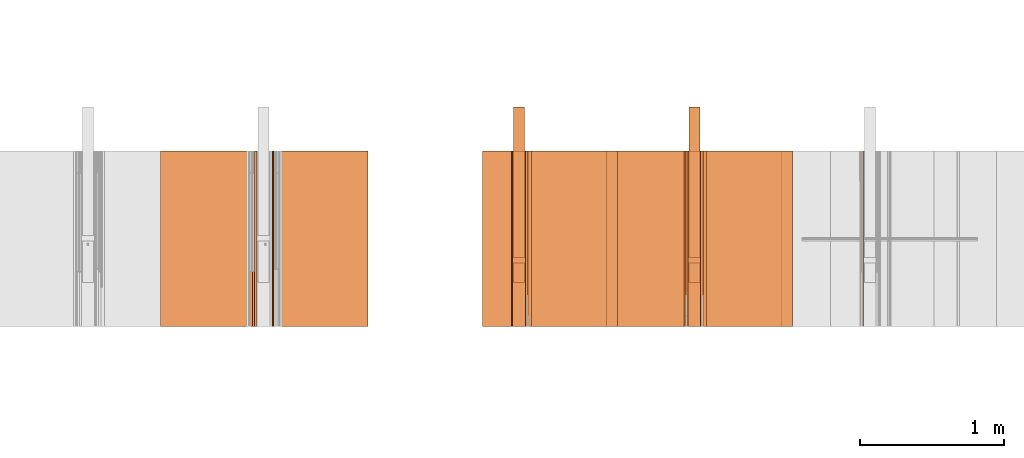
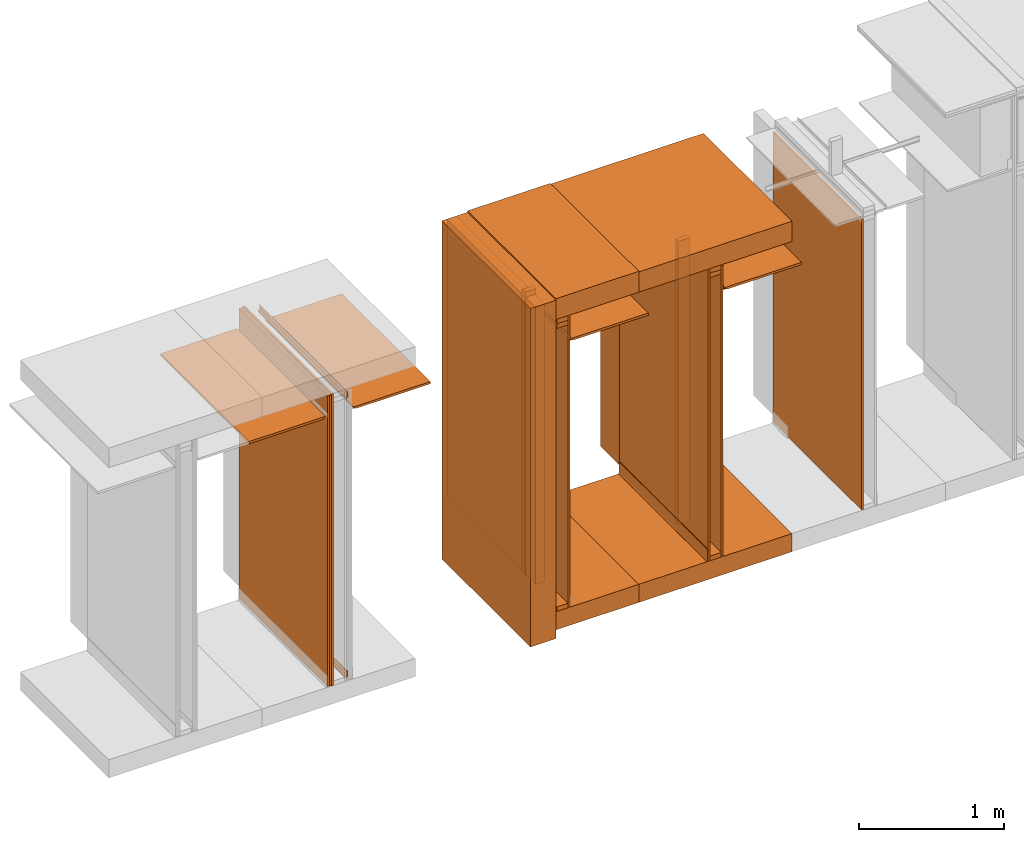
# One storey, part 33 of 64: 31 proxies.
"""IFC4 building model written with IfcOpenShell, lengths in feet."""

from ifc_helpers import new_model, entity, si_unit, converted_unit, frame, origin_with_axes, origin_2d_with_axis, place, context, subcontext, project, spatial, polyline, line, indexed_curve, outline, extrude, material, constituent, constituent_set, element, save


model = new_model("IFC4")

# Units and contexts
model_context_1 = context("Model", 3, precision=1e-05, world=origin_with_axes())
plan_context = context("Plan", 2, precision=1e-05, world=origin_2d_with_axis())
model_context_2 = context("Model", 3, precision=1e-05, world=origin_with_axes())
context_of_model_1 = context(None, 3, precision=1e-05, world=origin_with_axes())
context_of_model_2 = context(None, 3, precision=1e-05, world=origin_with_axes())
body_context = subcontext(model_context_2, "Body", "Model", "MODEL_VIEW")
ifc_project = project(units=[converted_unit("PLANEANGLEUNIT", "degree", entity("IfcReal", 0.0174532925199433), si_unit("PLANEANGLEUNIT", "RADIAN"), dimensions=[0, 0, 0, 0, 0, 0, 0]), converted_unit("AREAUNIT", "square foot", entity("IfcReal", 0.09290304), si_unit("AREAUNIT", "SQUARE_METRE"), dimensions=[2, 0, 0, 0, 0, 0, 0]), converted_unit("LENGTHUNIT", "foot", entity("IfcReal", 0.3048), si_unit("LENGTHUNIT", "METRE"), dimensions=[1, 0, 0, 0, 0, 0, 0]), converted_unit("VOLUMEUNIT", "cubic foot", entity("IfcReal", 0.0283168467116885), si_unit("VOLUMEUNIT", "CUBIC_METRE"), dimensions=[3, 0, 0, 0, 0, 0, 0])], contexts=[model_context_1, plan_context, context_of_model_1, context_of_model_2])

# Site, building, storey
site_placement = place(None, origin_with_axes())
site = spatial("IfcSite", under=ifc_project, at=site_placement)
building_placement = place(site_placement, origin_with_axes())
building = spatial("IfcBuilding", under=site, at=building_placement, Name="Building")
storey_placement = place(building_placement, origin_with_axes())
storey = spatial("IfcBuildingStorey", under=building, at=storey_placement, Name="Storey")

# Proxies
ifc_material_1 = material(Category="sand")
proxy_1_placement = place(storey_placement, frame((1378.99323711245, 5.99999987860051, 0.0208333330815585), z_axis=(4.37113882867379e-08, -0.999999999999999, -8.51092183247426e-15), x_axis=(1.94707183709394e-07, 0.0, 0.999999999999981)))
element("IfcBuildingElementProxy", 1, at=proxy_1_placement, inside=storey, material=ifc_material_1, Name="Generic Models 550:Generic Models 1", PredefinedType="COMPLEX", context=body_context, shape_type="SweptSolid", body=[
    extrude(outline(polyline([(-4.00429713757332, -0.0260416674977682), (4.00429713757332, -0.0260416674977682), (4.00429713757332, 0.0260416674977682), (-4.00429713757332, 0.0260416674977682), (-4.00429713757332, -0.0260416674977682)])), frame((4.00429713757332, -0.0260408883401024, -3.10444292028814e-09), z_axis=(-3.17388734109685e-14, 1.19209289550781e-07, -1.0), x_axis=(1.0, 1.94707183709397e-07, -8.51092267950722e-15)), (-1.26761878771475e-09, 8.29316199046914e-11, -1.0), 4.00000000752362),
])
ifc_constituent_set_1 = constituent_set(Name="concrete")
proxy_2_placement = place(storey_placement, frame((1373.18228173444, 5.99999987860051, -0.500000006179484), z_axis=(7.54979012640431e-08, -0.999999999999997, 5.69993288272772e-15), x_axis=(7.54979012640431e-08, 0.0, -0.999999999999997)))
element("IfcBuildingElementProxy", 2, at=proxy_2_placement, inside=storey, material=ifc_constituent_set_1, Name="Generic Models 11:Generic Models 1", PredefinedType="COMPLEX", context=body_context, shape_type="SweptSolid", body=[
    extrude(outline(polyline([(-0.249999905313094, -2.00000002471794), (0.250000174198876, -2.00000002471794), (0.249999880868932, 2.00000002471794), (-0.250000198643039, 2.00000002471794), (-0.249999905313094, -2.00000002471794)])), frame((-0.249999831980608, 2.00000002471794, -5.65952137880985e-07), z_axis=(0.0, -8.74227978897579e-08, -1.0), x_axis=(-1.0, 0.0, 0.0)), (0.0, 1.03538582152396e-08, -1.0), 4.00000000752362),
])
ifc_material_2 = material(Name="CEILING TRACK AS SCHEDULED", Category="poche")
proxy_3_placement = place(storey_placement, frame((1375.38539455944, 5.99999987860051, 7.35498241239332), z_axis=(7.54979012640431e-08, -0.999999999999997, 5.69993288272772e-15), x_axis=(7.54979012640431e-08, 0.0, -0.999999999999997)))
element("IfcBuildingElementProxy", 3, at=proxy_3_placement, inside=storey, material=ifc_material_2, Name="Generic Models 14:Generic Models 1", PredefinedType="COMPLEX", context=body_context, shape_type="SweptSolid", body=[
    extrude(outline(polyline([(-0.043402779162947, -0.029513890441908), (0.0815972223819241, -0.029513890441908), (0.0815972284929646, -0.0243055575534584), (-0.0381944432189771, -0.0243055575534584), (-0.0381944462744974, 0.0538194388288056), (-0.043402779162947, 0.0538194510508866), (-0.043402779162947, -0.029513890441908)])), frame((-0.0434019908387204, 0.0295138812753472, -3.93686786291257e-07), z_axis=(4.20818639808827e-14, -8.74224923563816e-08, -1.0), x_axis=(-1.0, 7.65208625352898e-08, 0.0)), (-1.99266270151099e-10, 2.64895128054832e-09, -1.0), 4.00000000752362),
])
proxy_4_placement = place(storey_placement, frame((1375.04167131239, 5.99999987860051, 7.81249968711472), z_axis=(7.54979012640431e-08, -0.999999999999997, 5.69993288272772e-15), x_axis=(7.54979012640431e-08, 0.0, -0.999999999999997)))
element("IfcBuildingElementProxy", 4, at=proxy_4_placement, inside=storey, Name="Generic Models 155:Generic Models 1", PredefinedType="COMPLEX", context=body_context, shape_type="SweptSolid", body=[
    extrude(outline(polyline([(-0.062500006883476, -0.145833333098669), (0.0625000007724355, -0.145833333098669), (0.062500006883476, 0.145833308654507), (-0.0625000007724355, 0.14583334532075), (-0.062500006883476, -0.145833333098669)])), frame((-0.0624991085605202, 0.145833320876588, -4.03855753155507e-07), z_axis=(0.0, -8.74228121006126e-08, -1.0), x_axis=(-1.0, 9.77766632104249e-08, 0.0)), (5.0926202144197e-10, -3.39597883147746e-09, -1.0), 4.00000000752362),
])
proxy_5_placement = place(storey_placement, frame((1375.06249695625, 2.99999993930026, 0.125000001544871), z_axis=(-1.62920684942944e-07, 0.999999999999987, -1.23001694617954e-14), x_axis=(7.54979012640431e-08, 0.0, -0.999999999999997)))
element("IfcBuildingElementProxy", 5, at=proxy_5_placement, inside=storey, Name="Generic Models 18:Generic Models 1", PredefinedType="COMPLEX", context=body_context, shape_type="SweptSolid", body=[
    extrude(outline(polyline([(-3.83239327453253, -0.12499998932279), (3.83239327453253, -0.12499998932279), (3.83239327453253, 0.125000013766952), (-3.83239327453253, 0.125000025989033), (-3.83239327453253, -0.12499998932279)])), frame((-3.83239327453253, -0.125000282652735, -4.20396346619738e-14), z_axis=(1.23001711558614e-14, 0.0, -1.0), x_axis=(0.999999940395355, 7.49450492776305e-08, 1.23001711558614e-14)), (-2.34202568449859e-09, 1.52774848327653e-09, -1.0), 4.00000000752362),
])
ifc_material_3 = material()
ifc_constituent = constituent(ifc_material_3)
ifc_constituent_set_2 = constituent_set(constituents=[ifc_constituent], Name="wood")
proxy_6_placement = place(storey_placement, frame((1375.04167131239, 5.99999987860051, -4.92006757396041e-14), z_axis=(7.54979012640431e-08, -0.999999999999997, 5.69993288272772e-15), x_axis=(7.54979012640431e-08, 0.0, -0.999999999999997)))
element("IfcBuildingElementProxy", 6, at=proxy_6_placement, inside=storey, material=ifc_constituent_set_2, Name="Generic Models 1:Generic Models 1", PredefinedType="COMPLEX", context=body_context, shape_type="SweptSolid", body=[
    extrude(outline(polyline([(-0.0624999641061924, -0.145833320876588), (0.0625000374386786, -0.145833320876588), (0.0624999579951519, 0.145833357542831), (-0.0625000435497191, 0.145833320876588), (-0.0624999641061924, -0.145833320876588)])), frame((-0.0624999885503545, 0.145833333098669, -4.03855753155507e-07), z_axis=(8.19452029832395e-15, -8.742281920604e-08, -1.0), x_axis=(1.0, 1.9555329799914e-07, 0.0)), (-5.09236153245496e-10, -1.18727372377947e-09, -1.0), 4.00000000752362),
])
proxy_7_placement = place(storey_placement, frame((1370.35419934691, 5.99999987860051, -0.741135700559366), z_axis=(7.54979012640431e-08, -0.999999999999997, 5.69993288272772e-15), x_axis=(7.54979012640431e-08, 0.0, -0.999999999999997)))
element("IfcBuildingElementProxy", 7, at=proxy_7_placement, inside=storey, Name="Generic Models 26:Generic Models 1", PredefinedType="COMPLEX", context=body_context, shape_type="SweptSolid", body=[
    extrude(outline(polyline([(-0.333333329304935, -4.66965471352805), (0.33333337819326, -4.66965471352805), (0.333333304860773, 4.66965471352805), (-0.333333329304935, 4.66965471352805), (-0.333333329304935, -4.66965471352805)])), frame((-4.66965471352805, 0.333333695967366, -4.20247517158809e-07), z_axis=(-1.15161688948276e-15, -8.74227765734759e-08, -1.0), x_axis=(-6.80508804862257e-08, -1.0, 8.74227623626211e-08)), (1.8681878266591e-09, 5.67091396064257e-09, -1.0), 4.00000000752362),
])
proxy_8_placement = place(storey_placement, frame((1375.33333044978, 5.99999987860051, 0.0208333330815585), z_axis=(7.54979012640431e-08, -0.999999999999997, 5.69993288272772e-15), x_axis=(7.54979012640431e-08, 0.0, -0.999999999999997)))
element("IfcBuildingElementProxy", 8, at=proxy_8_placement, inside=storey, material=ifc_material_1, Name="Generic Models 2:Generic Models 1", PredefinedType="COMPLEX", context=body_context, shape_type="SweptSolid", body=[
    extrude(outline(polyline([(-4.01041717354081, -0.0260416644422479), (4.01041717354081, -0.0260416644422479), (4.01041717354081, 0.0260416705532884), (-4.01041717354081, 0.0260416705532884), (-4.01041717354081, -0.0260416644422479)])), frame((-4.01041717354081, 0.026041973049794, -3.9338322042823e-07), z_axis=(-7.82204010086772e-16, -8.74215970725345e-08, -1.0), x_axis=(1.0, -7.54276925363229e-08, 5.8128042581141e-15)), (-4.91072238428814e-10, 3.39262007376107e-10, -1.0), 4.00000000752362),
])
proxy_9_placement = place(storey_placement, frame((1371.04164584102, 5.99999987860051, -4.92006757396041e-14), z_axis=(7.54979012640431e-08, -0.999999999999997, 5.69993288272772e-15), x_axis=(7.54979012640431e-08, 0.0, -0.999999999999997)))
element("IfcBuildingElementProxy", 9, at=proxy_9_placement, inside=storey, Name="Generic Models 36:Generic Models 1", PredefinedType="COMPLEX", context=body_context, shape_type="SweptSolid", body=[
    extrude(outline(polyline([(-0.0624999641061924, -0.145833320876588), (0.0625000374386786, -0.145833320876588), (0.0624999579951519, 0.145833357542831), (-0.0625000435497191, 0.145833320876588), (-0.0624999641061924, -0.145833320876588)])), frame((-0.0624999885503545, 0.145833333098669, -4.03855753155507e-07), z_axis=(8.19452029832395e-15, -8.742281920604e-08, -1.0), x_axis=(1.0, 1.9555329799914e-07, 0.0)), (-5.09236153245496e-10, -1.18727372377947e-09, -1.0), 4.00000000752362),
])
proxy_10_placement = place(storey_placement, frame((1371.38536908808, 5.99999987860051, 7.35498241239332), z_axis=(7.54979012640431e-08, -0.999999999999997, 5.69993288272772e-15), x_axis=(7.54979012640431e-08, 0.0, -0.999999999999997)))
element("IfcBuildingElementProxy", 10, at=proxy_10_placement, inside=storey, material=ifc_material_2, Name="Generic Models 454:Generic Models 1", PredefinedType="COMPLEX", context=body_context, shape_type="SweptSolid", body=[
    extrude(outline(polyline([(-0.0434027761074267, -0.029513890441908), (0.081597210159843, -0.029513890441908), (0.0815972162708836, -0.0243055575534584), (-0.0381944432189771, -0.0243055575534584), (-0.0381944432189771, 0.0538194388288056), (-0.0434027761074267, 0.0538194449398461), (-0.0434027761074267, -0.029513890441908)])), frame((-0.0434039097054424, 0.0295138812753472, -2.5801856277088e-09), z_axis=(4.20819995061543e-14, -8.74227765734759e-08, -1.0), x_axis=(-1.0, 7.65208696407171e-08, -6.68966674115539e-15)), (-1.99272875978096e-10, 2.64862309862224e-09, -1.0), 4.00000000752362),
])
ifc_material_4 = material(Name="UNDERSIDE OF FLOOR ASSEMBLY", Category="sand")
proxy_11_placement = place(storey_placement, frame((1373.18228173444, 5.99999987860051, 8.06249971464863), z_axis=(7.54979012640431e-08, -0.999999999999997, 5.69993288272772e-15), x_axis=(7.54979012640431e-08, 0.0, -0.999999999999997)))
element("IfcBuildingElementProxy", 11, at=proxy_11_placement, inside=storey, material=ifc_material_4, Name="Generic Models 499:Generic Models 1", PredefinedType="COMPLEX", context=body_context, shape_type="SweptSolid", body=[
    extrude(outline(polyline([(-0.279213050062575, -2.00000002471794), (0.279213318948358, -2.00000002471794), (0.279213025618413, 2.00000002471794), (-0.279213392280844, 2.00000002471794), (-0.279213050062575, -2.00000002471794)])), frame((-0.279211583412851, 2.00000002471794, -5.65952137880985e-07), z_axis=(0.0, -8.74227765734759e-08, -1.0), x_axis=(1.0, 0.0, 0.0)), (0.0, -1.03538813078785e-08, -1.0), 4.00000000752362),
])
ifc_material_5 = material(Name="STRUCTURAL FLOOR", Category="concrete")
proxy_12_placement = place(storey_placement, frame((1371.02082019716, 5.99999987860051, -0.500000006179484), z_axis=(7.54979012640431e-08, -0.999999999999997, 5.69993288272772e-15), x_axis=(7.54979012640431e-08, 0.0, -0.999999999999997)))
element("IfcBuildingElementProxy", 12, at=proxy_12_placement, inside=storey, material=ifc_material_5, Name="Generic Models 500:Generic Models 1", PredefinedType="COMPLEX", context=body_context, shape_type="SweptSolid", body=[
    extrude(outline(polyline([(-0.249999905313094, -1.0807292042129), (0.250000076422228, -1.0807292042129), (0.249999905313094, 1.0807292042129), (-0.250000051978066, 1.0807292042129), (-0.249999905313094, -1.0807292042129)])), frame((-0.249999954201418, 1.0807292042129, -4.85586957054172e-07), z_axis=(0.0, -8.74227907843306e-08, -1.0), x_axis=(1.0, 0.0, 0.0)), (0.0, -1.03538644324885e-08, -1.0), 4.00000000752362),
])
ifc_material_6 = material(Name="DOUBLE 2X WOOD TOP PLATE")
proxy_13_placement = place(storey_placement, frame((1375.04167131239, 5.99999987860051, 7.93749970088168), z_axis=(7.54979012640431e-08, -0.999999999999997, 5.69993288272772e-15), x_axis=(7.54979012640431e-08, 0.0, -0.999999999999997)))
element("IfcBuildingElementProxy", 13, at=proxy_13_placement, inside=storey, material=ifc_material_6, Name="Generic Models 6:Generic Models 1", PredefinedType="COMPLEX", context=body_context, shape_type="SweptSolid", body=[
    extrude(outline(polyline([(-0.062500006883476, -0.145833333098669), (0.0625000007724355, -0.145833333098669), (0.062500006883476, 0.145833308654507), (-0.0625000007724355, 0.14583334532075), (-0.062500006883476, -0.145833333098669)])), frame((-0.0624991085605202, 0.145833320876588, -4.03855753155507e-07), z_axis=(0.0, -8.74228121006126e-08, -1.0), x_axis=(-1.0, 9.77766632104249e-08, 0.0)), (5.0926202144197e-10, -3.39597883147746e-09, -1.0), 4.00000000752362),
])
ifc_constituent_set_3 = constituent_set(Name="poche")
proxy_14_placement = place(storey_placement, frame((1374.95506466843, 5.99999987860051, -4.92006757396041e-14), z_axis=(7.54979012640431e-08, -0.999999999999997, 5.69993288272772e-15), x_axis=(7.54979012640431e-08, 0.0, -0.999999999999997)))
element("IfcBuildingElementProxy", 14, at=proxy_14_placement, inside=storey, material=ifc_constituent_set_3, Name="Generic Models 42:Generic Models 1", PredefinedType="COMPLEX", context=body_context, shape_type="SweptSolid", body=[
    extrude(outline(polyline([(0.0865199099590616, -8.5939931170287e-10), (0.0746953398908373, -0.00423440261159747), (0.0621777228287512, -0.00526409536927665), (-0.213292693802378, 0.00819644836948456), (-0.218226039034175, 0.00642983669420005), (-0.220465222055831, 0.00169228920053075), (-0.220639508931343, -0.00187364654991962), (0.0616693270351161, -0.0156683412202074), (0.0768970805672523, -0.0144157215239104), (0.0912817488387814, -0.00926454596128559), (0.103843065951596, -0.000565859912790778), (0.113724972906075, 0.0110875258742883), (0.104968829613345, 0.0167299343732594), (0.0968456251199633, 0.00715054454907697), (0.0865199099590616, -8.5939931170287e-10)])), frame((-0.113048162946864, 0.0218330794490698, -3.93015360704795e-07), z_axis=(-2.55675960004337e-13, -8.74225420943731e-08, -1.0), x_axis=(0.998808324337006, -0.0488056913018227, 4.26736290748408e-09)), (-2.34471624338539e-08, 2.81413847780243e-09, -1.0), 4.00000000752362),
])
ifc_constituent_set_4 = constituent_set(Name="sand")
proxy_15_placement = place(storey_placement, frame((1374.98960720272, 5.99999987860051, 0.0208333330815585), z_axis=(7.54979012640431e-08, -0.999999999999997, 5.69993288272772e-15), x_axis=(7.54979012640431e-08, 0.0, -0.999999999999997)))
element("IfcBuildingElementProxy", 15, at=proxy_15_placement, inside=storey, material=ifc_constituent_set_4, Name="Generic Models 9:Generic Models 1", PredefinedType="COMPLEX", context=body_context, shape_type="SweptSolid", body=[
    extrude(outline(polyline([(-0.0260413650012626, -4.01041717354081), (0.0260419699942737, -4.01041717354081), (0.0260413650012626, 4.01041717354081), (-0.0260419699942737, 4.01041717354081), (-0.0260413650012626, -4.01041717354081)])), frame((-4.01041717354081, 0.0260419699942737, -3.9338322042823e-07), z_axis=(6.70460564948787e-16, -8.74218102353552e-08, -1.0), x_axis=(0.0, -1.0, 8.74220376090307e-08)), (3.39704930851781e-10, -7.28492803868429e-16, -1.0), 4.00000000752362),
])
proxy_16_placement = place(storey_placement, frame((1371.42962358129, 5.99999987860051, 7.33943123204189), z_axis=(7.54979012640431e-08, -0.999999999999997, 5.69993288272772e-15), x_axis=(7.54979012640431e-08, 0.0, -0.999999999999997)))
element("IfcBuildingElementProxy", 16, at=proxy_16_placement, inside=storey, Name="Generic Models 503:Generic Models 1", PredefinedType="COMPLEX", context=body_context, shape_type="SweptSolid", body=[
    extrude(outline(polyline([(0.640468627918424, -0.00347222294413981), (0.682135315470182, -0.00347222294413981), (0.682135315470182, 0.0329861103305275), (-1.31786466035943, 0.032986104219487), (-1.31786466035943, -0.029513890441908), (0.630990257413368, -0.0295138873863877), (0.640468627918424, -0.00347222294413981)])), frame((-0.0295149904292008, 0.682135315470182, -5.96341698681725e-08), z_axis=(0.0, -8.74227836789032e-08, -1.0), x_axis=(-7.33324512225408e-08, -1.0, 8.74227907843306e-08)), (-9.81275682931937e-09, 2.83582712867769e-10, -1.0), 4.00000000752362),
])
proxy_17_placement = place(storey_placement, frame((1371.04164584102, 3.44270835398376, 0.125000001544871), z_axis=(0.999999999999981, 0.0, 1.94707183709394e-07), x_axis=(1.94707183709394e-07, 0.0, -0.999999999999981)))
element("IfcBuildingElementProxy", 17, at=proxy_17_placement, inside=storey, Name="Generic Models 504:Generic Models 65", PredefinedType="COMPLEX", context=body_context, shape_type="SweptSolid", body=[
    extrude(outline(polyline([(-3.90624984355736, -0.0625000007724355), (3.90624984355736, -0.0625000007724355), (3.90624984355736, 0.0625000007724355), (-3.90624984355736, 0.0625000007724355), (-3.90624984355736, -0.0625000007724355)])), frame((-3.90624984355736, 0.0625000007724355, 2.94913769695501e-07), z_axis=(-7.54979012640433e-08, 0.0, -1.0), x_axis=(1.0, 0.0, -7.54979083694707e-08)), (-7.54979865291716e-08, 0.0, -1.0), 0.291666664589755),
])
proxy_18_placement = place(storey_placement, frame((1371.04164584102, 5.99999987860051, 7.81249968711472), z_axis=(7.54979012640431e-08, -0.999999999999997, 5.69993288272772e-15), x_axis=(7.54979012640431e-08, 0.0, -0.999999999999997)))
element("IfcBuildingElementProxy", 18, at=proxy_18_placement, inside=storey, Name="Generic Models 505:Generic Models 1", PredefinedType="COMPLEX", context=body_context, shape_type="SweptSolid", body=[
    extrude(outline(polyline([(-0.0624999579951519, -0.145833320876588), (0.0625000374386786, -0.145833320876588), (0.0624999579951519, 0.145833357542831), (-0.0625000374386786, 0.145833320876588), (-0.0624999579951519, -0.145833320876588)])), frame((-0.0625010213162017, 0.145833333098669, -4.03855753155507e-07), z_axis=(8.1945211453569e-15, -8.742281920604e-08, -1.0), x_axis=(1.0, 1.95553312209995e-07, 0.0)), (-5.0923543160053e-10, -1.187324571994e-09, -1.0), 4.00000000752362),
])
proxy_19_placement = place(storey_placement, frame((1371.06247148489, 2.99999993930026, 0.125000001544871), z_axis=(-1.62920684942944e-07, 0.999999999999987, -1.23001694617954e-14), x_axis=(7.54979012640431e-08, 0.0, -0.999999999999997)))
element("IfcBuildingElementProxy", 19, at=proxy_19_placement, inside=storey, Name="Generic Models 506:Generic Models 1", PredefinedType="COMPLEX", context=body_context, shape_type="SweptSolid", body=[
    extrude(outline(polyline([(-3.83239327453253, -0.125000001544871), (3.83239327453253, -0.125000001544871), (3.83239327453253, 0.125000013766952), (-3.83239327453253, 0.125000001544871), (-3.83239327453253, -0.125000001544871)])), frame((-3.83239327453253, -0.125000294874816, -4.20396346619738e-14), z_axis=(1.23001711558614e-14, 0.0, -1.0), x_axis=(-0.999999940395355, -7.65396208635138e-08, -1.23001694617955e-14)), (2.39185649064666e-09, 1.16558848618949e-14, -1.0), 4.00000000752362),
])
proxy_20_placement = place(storey_placement, frame((1371.04164584102, 5.99999987860051, 7.93749970088168), z_axis=(7.54979012640431e-08, -0.999999999999997, 5.69993288272772e-15), x_axis=(7.54979012640431e-08, 0.0, -0.999999999999997)))
element("IfcBuildingElementProxy", 20, at=proxy_20_placement, inside=storey, Name="Generic Models 508:Generic Models 1", PredefinedType="COMPLEX", context=body_context, shape_type="SweptSolid", body=[
    extrude(outline(polyline([(-0.0624999579951519, -0.145833320876588), (0.0625000374386786, -0.145833320876588), (0.0624999579951519, 0.145833357542831), (-0.0625000374386786, 0.145833320876588), (-0.0624999579951519, -0.145833320876588)])), frame((-0.0625010213162017, 0.145833333098669, -4.03855753155507e-07), z_axis=(8.1945211453569e-15, -8.742281920604e-08, -1.0), x_axis=(1.0, 1.95553312209995e-07, 0.0)), (-5.0923543160053e-10, -1.187324571994e-09, -1.0), 4.00000000752362),
])
proxy_21_placement = place(storey_placement, frame((1375.04167131239, 3.44270835398376, 0.125000001544871), z_axis=(0.999999999999981, 0.0, 1.94707183709394e-07), x_axis=(1.94707183709394e-07, 0.0, -0.999999999999981)))
element("IfcBuildingElementProxy", 21, at=proxy_21_placement, inside=storey, Name="Generic Models 52:Generic Models 65", PredefinedType="COMPLEX", context=body_context, shape_type="SweptSolid", body=[
    extrude(outline(polyline([(-3.90624984355736, -0.0625000007724355), (3.90624984355736, -0.0625000007724355), (3.90624984355736, 0.0625000007724355), (-3.90624984355736, 0.0625000007724355), (-3.90624984355736, -0.0625000007724355)])), frame((-3.90624984355736, 0.0625000007724355, 2.94913769695501e-07), z_axis=(-7.54979012640433e-08, 0.0, -1.0), x_axis=(-1.0, 0.0, 7.54979083694707e-08)), (7.54979865291716e-08, 0.0, -1.0), 0.291666664589755),
])
proxy_22_placement = place(storey_placement, frame((1371.33330497842, 5.99999987860051, 0.0208333330815585), z_axis=(7.54979012640431e-08, -0.999999999999997, 5.69993288272772e-15), x_axis=(7.54979012640431e-08, 0.0, -0.999999999999997)))
element("IfcBuildingElementProxy", 22, at=proxy_22_placement, inside=storey, material=ifc_material_1, Name="Generic Models 67:Generic Models 1", PredefinedType="COMPLEX", context=body_context, shape_type="SweptSolid", body=[
    extrude(outline(polyline([(-0.0260413650012626, -4.01041717354081), (0.0260419699942737, -4.01041717354081), (0.0260413650012626, 4.01041717354081), (-0.0260419699942737, 4.01041717354081), (-0.0260413650012626, -4.01041717354081)])), frame((-4.01041717354081, 0.0260419699942737, -3.9338322042823e-07), z_axis=(-7.82204010086772e-16, -8.74215970725345e-08, -1.0), x_axis=(0.0, 1.0, -8.74215899671071e-08)), (-3.39256178705227e-10, -7.28492803868429e-16, -1.0), 4.00000000752362),
])
proxy_23_placement = place(storey_placement, frame((1371.02082019716, 5.99999987860051, 8.06249971464863), z_axis=(7.54979012640431e-08, -0.999999999999997, 5.69993288272772e-15), x_axis=(7.54979012640431e-08, 0.0, -0.999999999999997)))
element("IfcBuildingElementProxy", 23, at=proxy_23_placement, inside=storey, material=ifc_material_4, Name="Generic Models 7:Generic Models 1", PredefinedType="COMPLEX", context=body_context, shape_type="SweptSolid", body=[
    extrude(outline(polyline([(-0.288976855048044, -1.0807292042129), (0.288976855048044, -1.0807292042129), (0.288976855048044, 1.0807292042129), (-0.288976879492207, 1.0807292042129), (-0.288976855048044, -1.0807292042129)])), frame((-0.288977808370365, 1.0807292042129, -4.85586957054172e-07), z_axis=(0.0, -8.74227978897579e-08, -1.0), x_axis=(-1.0, 6.78546427934634e-08, 0.0)), (8.74191364642115e-15, 5.45173683974554e-09, -1.0), 4.00000000752362),
])
proxy_24_placement = place(storey_placement, frame((1375.42964905266, 5.99999987860051, 7.33943123204189), z_axis=(7.54979012640431e-08, -0.999999999999997, 5.69993288272772e-15), x_axis=(7.54979012640431e-08, 0.0, -0.999999999999997)))
element("IfcBuildingElementProxy", 24, at=proxy_24_placement, inside=storey, Name="Generic Models 49:Generic Models 1", PredefinedType="COMPLEX", context=body_context, shape_type="SweptSolid", body=[
    extrude(outline(polyline([(0.640468627918424, -0.00347222599966007), (0.682135315470182, -0.00347222599966007), (0.682135315470182, 0.0329861194970883), (-1.31786466035943, 0.0329861133860478), (-1.31786475813608, -0.0295138965529485), (0.630990257413368, -0.0295138934974282), (0.640468627918424, -0.00347222599966007)])), frame((-0.0295130746179991, 0.682135315470182, -4.50740757054604e-07), z_axis=(0.0, -8.74227836789032e-08, -1.0), x_axis=(-7.33324512225408e-08, -1.0, 8.74224497238174e-08)), (-9.81314229875352e-09, 2.83582712867769e-10, -1.0), 4.00000000752362),
])
proxy_25_placement = place(storey_placement, frame((1365.74212021715, 5.99999987860051, 7.43870660075991), z_axis=(4.37113882867379e-08, -0.999999999999999, -8.51092183247426e-15), x_axis=(1.94707183709394e-07, 0.0, 0.999999999999981)))
element("IfcBuildingElementProxy", 25, at=proxy_25_placement, inside=storey, Name="Generic Models 27:Generic Models 1", PredefinedType="COMPLEX", context=body_context, shape_type="SweptSolid", body=[
    extrude(outline(polyline([(-0.0329863700497495, -1.31786475813608), (0.0295136337782063, -1.31786475813608), (0.0295140126627183, 0.630990257413368), (0.00347234516495013, 0.640468627918424), (0.0034723543315109, 0.682135315470182), (-0.0329859789431564, 0.682135315470182), (-0.0329863700497495, -1.31786475813608)])), frame((0.0295140218292791, -0.682135315470182, -4.7242345352113e-07), z_axis=(5.53375813054646e-13, 1.19209303761636e-07, -1.0), x_axis=(-1.0, 0.0, 0.0)), (0.0, -3.01151925619081e-09, -1.0), 4.00000000752362),
])
for number, where, z_axis, x_axis, name in (
    (26, (1365.55208621688, 5.99999987860051, 0.0530653547622713), (4.37113882867379e-08, -0.999999999999999, -8.51092183247426e-15), (1.94707183709394e-07, 0.0, 0.999999999999981), "Generic Models 337:Generic Models 1"),
    (27, (1365.55208621688, 5.99999987860051, 7.76139848188465), (4.37113882867379e-08, -0.999999999999999, -8.51092183247426e-15), (1.94707183709394e-07, 0.0, 0.999999999999981), "Generic Models 338:Generic Models 1"),
):
    element("IfcBuildingElementProxy", number, at=place(storey_placement, frame(where, z_axis=z_axis, x_axis=x_axis)), inside=storey, Name=name, PredefinedType="COMPLEX", context=body_context, shape_type="SweptSolid", body=[
        extrude(outline(polyline([(0.0667668759255741, 0.0152567137531408), (0.106276176732982, 0.0152567137531408), (0.106276176732982, 0.0204650481693505), (0.0646095075143447, 0.0204650481693505), (0.0281511742396774, -0.0159932851053168), (-0.089483129061035, -0.0159932866330769), (-0.108790967681902, 0.00331456230017124), (-0.112473822915022, -0.000368285962543022), (-0.0916404974722643, -0.0212016195215265), (0.0303085395953865, -0.0212016210492867), (0.0667668759255741, 0.0152567137531408)])), frame((0.106276176732982, -0.0204650283084689, -3.93546216320895e-07), z_axis=(-2.48385014813002e-12, 1.19210000093517e-07, -1.0), x_axis=(-1.0, -1.93341818999215e-07, 0.0)), (9.89209492097132e-10, -1.26986490767145e-10, -1.0), 4.00000000752362),
    ])
proxy_26_placement = place(storey_placement, frame((1365.15629886016, 5.99999987860051, 0.0), z_axis=(4.37113882867379e-08, -0.999999999999999, -8.51092183247426e-15), x_axis=(1.94707183709394e-07, 0.0, 0.999999999999981)))
element("IfcBuildingElementProxy", 28, at=proxy_26_placement, inside=storey, Name="Generic Models 339:Generic Models 1", PredefinedType="COMPLEX", context=body_context, shape_type="SweptSolid", body=[
    extrude(outline(polyline([(-4.03124985732431, -0.0260416644422479), (4.03124985732431, -0.0260416644422479), (4.03124985732431, 0.0260416705532884), (-4.03124985732431, 0.0260416705532884), (-4.03124985732431, -0.0260416644422479)])), frame((4.03124985732431, -0.0260408852845821, -3.94211021364806e-07), z_axis=(-2.89920844764261e-14, 1.19209147442234e-07, -1.0), x_axis=(-1.0, -1.9479534785205e-07, 5.7827646581562e-15)), (1.26818977541632e-09, 4.38494379695342e-11, -1.0), 4.00000000752362),
])
proxy_27_placement = place(storey_placement, frame((1365.10413462721, 5.99999987860051, 0.0208333330815585), z_axis=(4.37113882867379e-08, -0.999999999999999, -8.51092183247426e-15), x_axis=(1.94707183709394e-07, 0.0, 0.999999999999981)))
element("IfcBuildingElementProxy", 29, at=proxy_27_placement, inside=storey, Name="Generic Models 340:Generic Models 1", PredefinedType="COMPLEX", context=body_context, shape_type="SweptSolid", body=[
    extrude(outline(polyline([(-0.0260416674977682, -4.01041717354081), (0.0260416674977682, -4.01041717354081), (0.0260416674977682, 4.01041717354081), (-0.0260416644422479, 4.01041717354081), (-0.0260416674977682, -4.01041717354081)])), frame((4.01041717354081, -0.0260408852845821, -3.94210974741267e-07), z_axis=(-2.90532910771947e-14, 1.19209140336807e-07, -1.0), x_axis=(-1.94707169498542e-07, 1.0, 1.19209147442234e-07)), (3.82907483498229e-10, -1.26761567909028e-09, -1.0), 4.00000000752362),
])
proxy_28_placement = place(storey_placement, frame((1363.0078533503, 5.99999987860051, 7.43870660075991), z_axis=(4.37113882867379e-08, -0.999999999999999, -8.51092183247426e-15), x_axis=(1.94707183709394e-07, 0.0, 0.999999999999981)))
element("IfcBuildingElementProxy", 30, at=proxy_28_placement, inside=storey, Name="Generic Models 37:Generic Models 1", PredefinedType="COMPLEX", context=body_context, shape_type="SweptSolid", body=[
    extrude(outline(polyline([(-1.31786475813608, -0.0329861103305275), (0.682135266581858, -0.0329861103305275), (0.682135266581858, 0.00347222599966007), (0.640468530141775, 0.0034722240899599), (0.630990257413368, 0.0295138934974282), (-1.31786475813608, 0.029513890441908), (-1.31786475813608, -0.0329861103305275)])), frame((0.0295141471056097, -1.31786475813608, -5.48208291244019e-07), z_axis=(0.0, 1.19209289550781e-07, -1.0), x_axis=(1.9555329799914e-07, -1.0, -1.19209303761636e-07)), (4.4544163912974e-09, 2.62274896245529e-10, -1.0), 4.00000000752362),
])
proxy_29_placement = place(storey_placement, frame((1365.05207051755, 5.99999987860051, 0.0208333330815585), z_axis=(4.37113882867379e-08, -0.999999999999999, -8.51092183247426e-15), x_axis=(1.94707183709394e-07, 0.0, 0.999999999999981)))
element("IfcBuildingElementProxy", 31, at=proxy_29_placement, inside=storey, material=ifc_material_1, Name="Generic Models 571:Generic Models 1", PredefinedType="COMPLEX", context=body_context, shape_type="SweptSolid", body=[
    extrude(outline(indexed_curve([(-4.01041717354081, -0.0260416674977682), (4.01041717354081, -0.0260416674977682), (4.01041717354081, 0.0260416644422479), (-4.01041717354081, 0.0260416674977682)], segments=[line(4, 1), line(1, 2), line(2, 3), line(3, 4)], self_intersect=False)), frame((4.01041717354081, -0.0260408852845821, -3.94211021364806e-07), z_axis=(-2.90532910771947e-14, 1.19209140336807e-07, -1.0), x_axis=(1.0, 1.94707197920252e-07, -5.8128042581141e-15)), (-1.26761612317949e-09, -3.82860854131195e-10, -1.0), 4.00000000752362),
])

save(model, "model.ifc")
